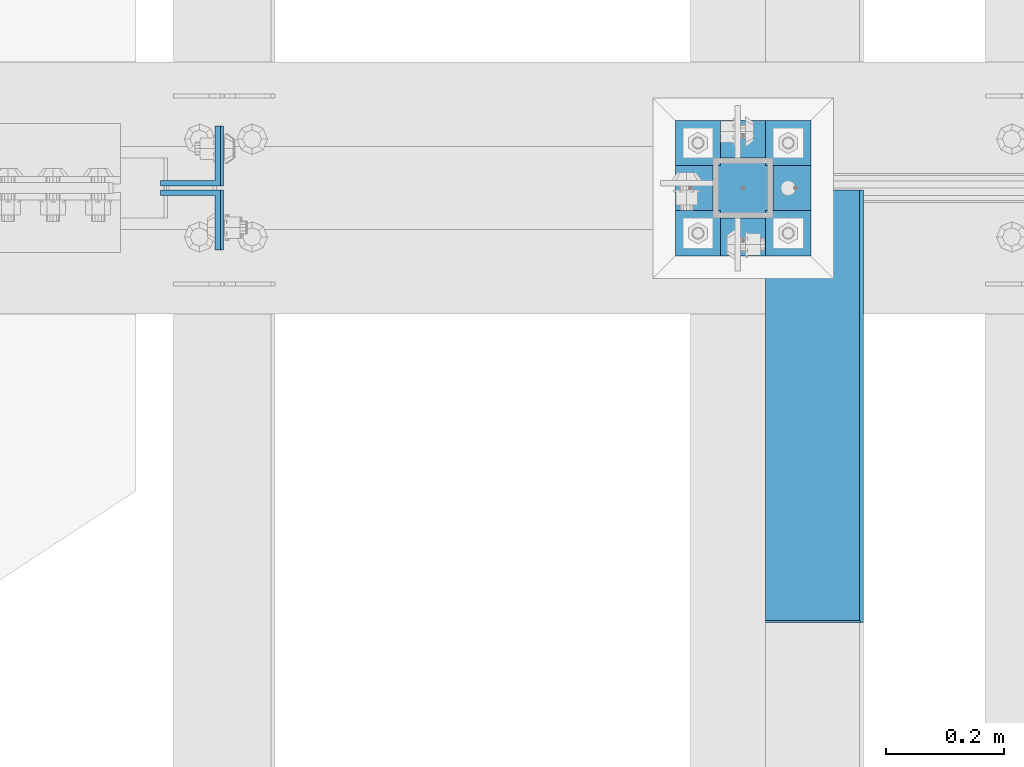
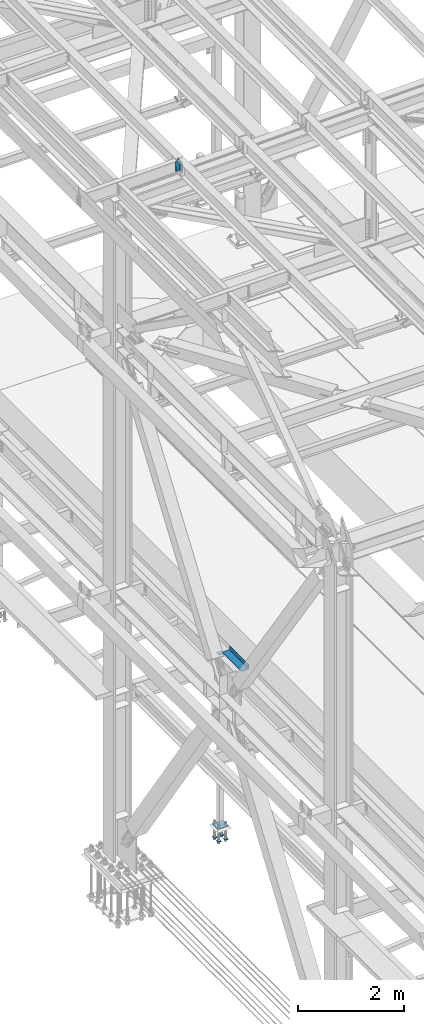
# One storey, part 2390 of 3843: 7 beams, 2 members, 4 elements without a shape of their own.
"""IFC2X3 building model written with IfcOpenShell, lengths in millimetres."""

from ifc_helpers import new_model, si_unit, frame, origin_with_axes, place, context, subcontext, project, spatial, faceted_brep, material, type_object, element, aggregate, save


model = new_model("IFC2X3")

# Units and contexts
model_context = context("Model", 3, precision=1e-05, world=origin_with_axes())
body_context = subcontext(model_context, "Body", "Model", "MODEL_VIEW")
ifc_project = project(units=[si_unit("LENGTHUNIT", "METRE", prefix="MILLI"), si_unit("AREAUNIT", "SQUARE_METRE"), si_unit("VOLUMEUNIT", "CUBIC_METRE"), si_unit("MASSUNIT", "GRAM", prefix="KILO"), si_unit("TIMEUNIT", "SECOND"), si_unit("PLANEANGLEUNIT", "RADIAN"), si_unit("SOLIDANGLEUNIT", "STERADIAN"), si_unit("THERMODYNAMICTEMPERATUREUNIT", "DEGREE_CELSIUS"), si_unit("LUMINOUSINTENSITYUNIT", "LUMEN")], contexts=[model_context])

# Site, building, storey
site_placement = place(None, origin_with_axes())
site = spatial("IfcSite", under=ifc_project, at=site_placement, CompositionType="ELEMENT")
building_placement = place(site_placement, origin_with_axes())
building = spatial("IfcBuilding", under=site, at=building_placement, Name="Undefined", CompositionType="ELEMENT")
storey_placement = place(building_placement, origin_with_axes())
storey = spatial("IfcBuildingStorey", under=building, at=storey_placement, Name="Undefined", CompositionType="ELEMENT", Elevation=0.0)

# Assembly, beam
assembly_1_placement = place(storey_placement, origin_with_axes())
assembly_1 = element("IfcElementAssembly", 1, at=assembly_1_placement, inside=storey, Name="BEAM", AssemblyPlace="NOTDEFINED", PredefinedType="RIGID_FRAME")
ifc_material_1 = material(Name="STEEL/A36")
beam_type_1 = type_object("IfcBeamType", PredefinedType="NOTDEFINED")
beam_1_placement = place(assembly_1_placement, frame((38858.825, 75260.2, 34039.175), z_axis=(0.0, -1.0, 0.0), x_axis=(1.0, 0.0, 0.0)))
beam_1 = element("IfcBeam", 2, at=beam_1_placement, type_object=beam_type_1, material=ifc_material_1, Name="BENT_PLATE", context=body_context, shape_type="Brep", body=[
    faceted_brep([(161.925005912773, 7.27595761418343e-12, 365.125000000029), (158.749999999993, 3.17500000000291, 361.950000000041), (0.0, 3.17500000000291, 361.950000000041), (0.0, 0.0, 365.125), (161.924999999988, 98.4249999999956, 365.125), (158.749999999993, 98.4249999999956, 361.950000000041), (165.099999999999, -3.17500000000291, -365.125), (0.0, -3.17500000000291, -365.125), (0.0, 3.17500000000291, -365.125), (158.749999999993, 3.17500000000291, -365.125), (158.749999999993, 98.4249999999956, -365.125), (165.099999999999, 98.4249999999956, -365.125), (165.099999999999, -3.17500000000291, 365.125), (165.099999999999, 98.4249999999956, 365.125), (0.0, -3.17500000000291, 365.125)], [[[0, 1, 2, 3]], [[4, 5, 1, 0]], [[6, 7, 8, 9, 10, 11]], [[12, 6, 11, 13]], [[14, 7, 6, 12]], [[8, 7, 14, 3, 2]], [[9, 8, 2, 1]], [[10, 9, 1, 5]], [[13, 11, 10, 5, 4]], [[14, 12, 13, 4, 0, 3]]]),
])
aggregate(assembly_1, [beam_1])

# Assembly, members
assembly_2_placement = place(storey_placement, origin_with_axes())
assembly_2 = element("IfcElementAssembly", 3, at=assembly_2_placement, inside=storey, Name="BEAM", AssemblyPlace="NOTDEFINED", PredefinedType="RIGID_FRAME")
ifc_material_2 = material(Name="STEEL/A572-50")
member_type = type_object("IfcMemberType", Name="L4X4X3/8", PredefinedType="NOTDEFINED")
member_1_placement = place(assembly_2_placement, frame((37892.6968634871, 75682.4749999525, 45497.6994958802), z_axis=(0.0, 1.0, 0.0), x_axis=(-0.0211520980073474, 0.0, 0.999776269347241)))
member_1 = element("IfcMember", 4, at=member_1_placement, type_object=member_type, material=ifc_material_2, Name="ANGLE", ObjectType="L4X4X3/8", context=body_context, shape_type="Brep", body=[
    faceted_brep([(0.0, 50.8000000000029, -50.8000000000029), (0.0, 50.8000000000029, 50.8000000000029), (228.599999994367, 50.7999999996973, 50.8000000000029), (228.599999994367, 50.7999999996973, -50.8000000000029), (0.0, 41.2750000000015, 50.8000000000029), (228.599999994345, 41.2749999997031, 50.8000000000029), (0.0, 41.2749999999942, -41.2750000000015), (228.599999994345, 41.2749999997031, -41.2750000000015), (0.0, -50.8000000000029, -41.2750000000015), (228.599999994258, -50.8000000001412, -41.2750000000015), (0.0, -50.8000000000029, -50.8000000000029), (228.599999994258, -50.8000000001412, -50.8000000000029)], [[[0, 1, 2, 3]], [[1, 4, 5, 2]], [[4, 6, 7, 5]], [[6, 8, 9, 7]], [[8, 10, 11, 9]], [[10, 0, 3, 11]], [[5, 7, 9, 11, 3, 2]], [[10, 8, 6, 4, 1, 0]]]),
])
member_2_placement = place(assembly_2_placement, frame((37887.8614952524, 75574.5250000479, 45726.2483510775), z_axis=(0.0, -1.0, 0.0), x_axis=(0.0211520550054438, 0.0, -0.999776270257025)))
member_2 = element("IfcMember", 5, at=member_2_placement, type_object=member_type, material=ifc_material_2, Name="ANGLE", ObjectType="L4X4X3/8", context=body_context, shape_type="Brep", body=[
    faceted_brep([(0.0, 50.8000000000029, -50.8000000000029), (0.0, 50.8000000000029, 50.8000000000029), (228.599999994367, 50.7999999996973, 50.8000000000029), (228.599999994367, 50.7999999996973, -50.8000000000029), (0.0, 41.2750000000015, 50.8000000000029), (228.599999994345, 41.2749999997031, 50.8000000000029), (0.0, 41.2749999999942, -41.2750000000015), (228.599999994345, 41.2749999997031, -41.2750000000015), (0.0, -50.8000000000029, -41.2750000000015), (228.599999994258, -50.8000000001412, -41.2750000000015), (0.0, -50.8000000000029, -50.8000000000029), (228.599999994258, -50.8000000001412, -50.8000000000029)], [[[0, 1, 2, 3]], [[1, 4, 5, 2]], [[4, 6, 7, 5]], [[6, 8, 9, 7]], [[8, 10, 11, 9]], [[10, 0, 3, 11]], [[5, 7, 9, 11, 3, 2]], [[10, 8, 6, 4, 1, 0]]]),
])
aggregate(assembly_2, [member_1, member_2])

# Assembly, beam
assembly_3_placement = place(storey_placement, origin_with_axes())
assembly_3 = element("IfcElementAssembly", 6, at=assembly_3_placement, inside=storey, Name="COLUMN", AssemblyPlace="NOTDEFINED", PredefinedType="RIGID_FRAME")
beam_type_2 = type_object("IfcBeamType", PredefinedType="NOTDEFINED")
beam_2_placement = place(assembly_3_placement, frame((38871.525, 75628.5, 34029.65), z_axis=(0.0, 1.0, 0.0), x_axis=(-1.0, 0.0, 0.0)))
beam_2 = element("IfcBeam", 7, at=beam_2_placement, type_object=beam_type_2, material=ifc_material_2, Name="PLATE", context=body_context, shape_type="Brep", body=[
    faceted_brep([(0.0, 6.34999999999854, -50.8000000000029), (0.0, 6.35000000000582, 50.7999992361001), (101.600000000006, 6.34999999999854, 50.8000000000029), (101.600000000006, 6.34999999999854, -50.8000000000029), (0.0, -6.35000000000582, 50.7999992361001), (101.600000000006, -6.34999999999854, 50.8000000000029), (0.0, -6.34999999999854, -50.8000000000029), (101.600000000006, -6.34999999999854, -50.8000000000029)], [[[0, 1, 2, 3]], [[1, 4, 5, 2]], [[4, 6, 7, 5]], [[6, 0, 3, 7]], [[5, 7, 3, 2]], [[6, 4, 1, 0]]]),
])
aggregate(assembly_3, [beam_2])

# Assembly, beams
assembly_4_placement = place(storey_placement, origin_with_axes())
assembly_4 = element("IfcElementAssembly", 8, at=assembly_4_placement, inside=storey, Name="TEMPLATE", AssemblyPlace="NOTDEFINED", PredefinedType="RIGID_FRAME")
beam_type_3 = type_object("IfcBeamType", PredefinedType="NOTDEFINED")
beam_3_placement = place(assembly_4_placement, frame((38935.025, 75552.3, 29762.45), z_axis=(0.0, 1.0, 0.0), x_axis=(-1.0, 0.0, 0.0)))
beam_3 = element("IfcBeam", 9, at=beam_3_placement, type_object=beam_type_3, material=ifc_material_2, context=body_context, shape_type="Brep", body=[
    faceted_brep([(0.0, 6.34999999999854, -38.1000000000058), (0.0, 6.34999999999854, 38.0999984741211), (76.1999999999971, 6.34999999999854, 38.1000000000058), (76.1999999999971, 6.34999999999854, -38.1000000000058), (0.0, -6.34999999999854, 38.0999984741211), (76.1999999999971, -6.34999999999854, 38.1000000000058), (0.0, -6.34999999999854, -38.1000000000058), (76.1999999999971, -6.34999999999854, -38.1000000000058)], [[[0, 1, 2, 3]], [[1, 4, 5, 2]], [[4, 6, 7, 5]], [[6, 0, 3, 7]], [[5, 7, 3, 2]], [[6, 4, 1, 0]]]),
])
beam_4_placement = place(assembly_4_placement, frame((38935.025, 75704.7, 29762.45), z_axis=(0.0, 1.0, 0.0), x_axis=(-1.0, 0.0, 0.0)))
beam_4 = element("IfcBeam", 10, at=beam_4_placement, type_object=beam_type_3, material=ifc_material_2, context=body_context, shape_type="Brep", body=[
    faceted_brep([(0.0, 6.34999999999854, -38.1000000000058), (0.0, 6.34999999999854, 38.0999984741211), (76.1999999999971, 6.34999999999854, 38.1000000000058), (76.1999999999971, 6.34999999999854, -38.1000000000058), (0.0, -6.34999999999854, 38.0999984741211), (76.1999999999971, -6.34999999999854, 38.1000000000058), (0.0, -6.34999999999854, -38.1000000000058), (76.1999999999971, -6.34999999999854, -38.1000000000058)], [[[0, 1, 2, 3]], [[1, 4, 5, 2]], [[4, 6, 7, 5]], [[6, 0, 3, 7]], [[5, 7, 3, 2]], [[6, 4, 1, 0]]]),
])
beam_5_placement = place(assembly_4_placement, frame((38782.625, 75552.3, 29762.45), z_axis=(0.0, 1.0, 0.0), x_axis=(-1.0, 0.0, 0.0)))
beam_5 = element("IfcBeam", 11, at=beam_5_placement, type_object=beam_type_3, material=ifc_material_2, context=body_context, shape_type="Brep", body=[
    faceted_brep([(0.0, 6.34999999999854, -38.1000000000058), (0.0, 6.34999999999854, 38.0999984741211), (76.1999999999971, 6.34999999999854, 38.1000000000058), (76.1999999999971, 6.34999999999854, -38.1000000000058), (0.0, -6.34999999999854, 38.0999984741211), (76.1999999999971, -6.34999999999854, 38.1000000000058), (0.0, -6.34999999999854, -38.1000000000058), (76.1999999999971, -6.34999999999854, -38.1000000000058)], [[[0, 1, 2, 3]], [[1, 4, 5, 2]], [[4, 6, 7, 5]], [[6, 0, 3, 7]], [[5, 7, 3, 2]], [[6, 4, 1, 0]]]),
])
beam_6_placement = place(assembly_4_placement, frame((38782.625, 75704.7, 29762.45), z_axis=(0.0, 1.0, 0.0), x_axis=(-1.0, 0.0, 0.0)))
beam_6 = element("IfcBeam", 12, at=beam_6_placement, type_object=beam_type_3, material=ifc_material_2, context=body_context, shape_type="Brep", body=[
    faceted_brep([(0.0, 6.34999999999854, -38.1000000000058), (0.0, 6.34999999999854, 38.0999984741211), (76.1999999999971, 6.34999999999854, 38.1000000000058), (76.1999999999971, 6.34999999999854, -38.1000000000058), (0.0, -6.34999999999854, 38.0999984741211), (76.1999999999971, -6.34999999999854, 38.1000000000058), (0.0, -6.34999999999854, -38.1000000000058), (76.1999999999971, -6.34999999999854, -38.1000000000058)], [[[0, 1, 2, 3]], [[1, 4, 5, 2]], [[4, 6, 7, 5]], [[6, 0, 3, 7]], [[5, 7, 3, 2]], [[6, 4, 1, 0]]]),
])
beam_type_4 = type_object("IfcBeamType", PredefinedType="NOTDEFINED")
beam_7_placement = place(assembly_4_placement, frame((38935.025, 75628.5, 30062.4875), z_axis=(0.0, -1.0, 0.0), x_axis=(-1.0, 0.0, 0.0)))
beam_7 = element("IfcBeam", 13, at=beam_7_placement, type_object=beam_type_4, material=ifc_material_2, Name="TEMPLATE", context=body_context, shape_type="Brep", body=[
    faceted_brep([(0.0, 1.58750000000146, -114.300000000003), (0.0, 1.58750000000146, 114.300000000003), (228.600000000006, 1.58750000000146, 114.300000000003), (228.600000000006, 1.58750000000146, -114.300000000003), (0.0, -1.58750000000146, 114.300000000003), (228.600000000006, -1.58750000000146, 114.300000000003), (0.0, -1.58750000000146, -114.300000000003), (228.600000000006, -1.58750000000146, -114.300000000003)], [[[0, 1, 2, 3]], [[1, 4, 5, 2]], [[4, 6, 7, 5]], [[6, 0, 3, 7]], [[5, 7, 3, 2]], [[6, 4, 1, 0]]]),
])
aggregate(assembly_4, [beam_3, beam_4, beam_5, beam_6, beam_7])

save(model, "model.ifc")
